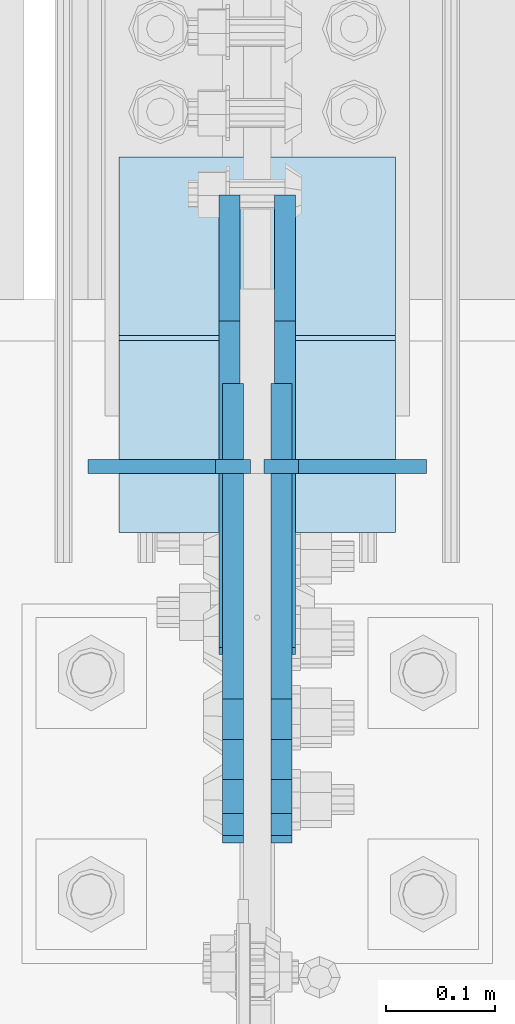
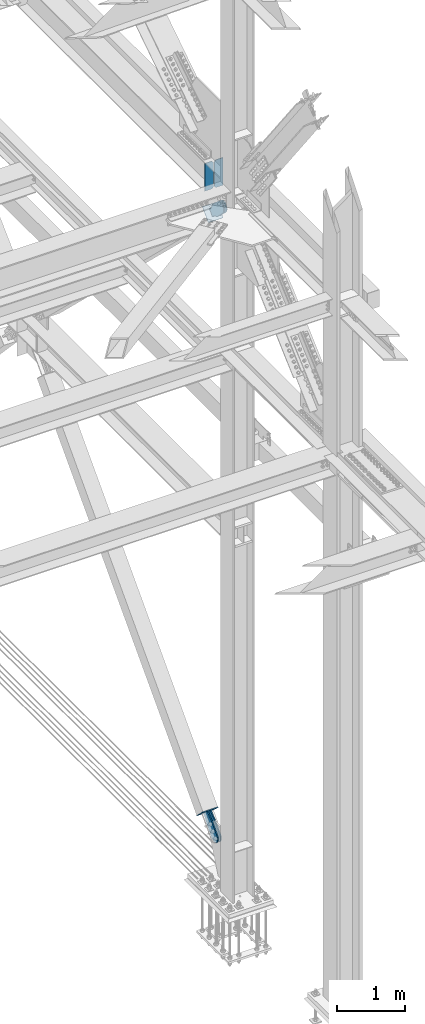
# One storey, part 3635 of 3843: 8 plates, 7 elements without a shape of their own.
"""IFC2X3 building model written with IfcOpenShell, lengths in millimetres."""

from ifc_helpers import new_model, si_unit, frame, origin_with_axes, place, context, subcontext, project, spatial, faceted_brep, material, type_object, element, aggregate, save


model = new_model("IFC2X3")

# Units and contexts
model_context = context("Model", 3, precision=1e-05, world=origin_with_axes())
body_context = subcontext(model_context, "Body", "Model", "MODEL_VIEW")
ifc_project = project(units=[si_unit("LENGTHUNIT", "METRE", prefix="MILLI"), si_unit("AREAUNIT", "SQUARE_METRE"), si_unit("VOLUMEUNIT", "CUBIC_METRE"), si_unit("MASSUNIT", "GRAM", prefix="KILO"), si_unit("TIMEUNIT", "SECOND"), si_unit("PLANEANGLEUNIT", "RADIAN"), si_unit("SOLIDANGLEUNIT", "STERADIAN"), si_unit("THERMODYNAMICTEMPERATUREUNIT", "DEGREE_CELSIUS"), si_unit("LUMINOUSINTENSITYUNIT", "LUMEN")], contexts=[model_context])

# Site, building, storey
site_placement = place(None, origin_with_axes())
site = spatial("IfcSite", under=ifc_project, at=site_placement, CompositionType="ELEMENT")
building_placement = place(site_placement, origin_with_axes())
building = spatial("IfcBuilding", under=site, at=building_placement, Name="Undefined", CompositionType="ELEMENT")
storey_placement = place(building_placement, origin_with_axes())
storey = spatial("IfcBuildingStorey", under=building, at=storey_placement, Name="Undefined", CompositionType="ELEMENT", Elevation=0.0)

# Assembly, plates
assembly_1_placement = place(storey_placement, origin_with_axes())
assembly_1 = element("IfcElementAssembly", 1, at=assembly_1_placement, inside=storey, Name="BEAM", AssemblyPlace="NOTDEFINED", PredefinedType="RIGID_FRAME")
ifc_material_1 = material(Name="STEEL/A572-50")
plate_type_1 = type_object("IfcPlateType", PredefinedType="NOTDEFINED")
plate_1_placement = place(assembly_1_placement, frame((85642.45, 92912.1863422609, 41948.1), z_axis=(0.0, 0.0, 1.0), x_axis=(-1.0, 0.0, 0.0)))
plate_1 = element("IfcPlate", 2, at=plate_1_placement, type_object=plate_type_1, material=ifc_material_1, Name="PLATE", context=body_context, shape_type="Brep", body=[
    faceted_brep([(0.0, -6.35000000000582, 31.75), (0.0, -6.35000000000582, 466.724999999999), (0.0, 6.35000000000582, 466.724999999999), (0.0, 6.35000000000582, 31.75), (31.75, -6.35000000000582, 498.474999999999), (31.75, 6.35000000000582, 498.474999999999), (149.224999999991, -6.35000000000582, 498.474999999999), (149.224999999991, 6.35000000000582, 498.474999999999), (149.224999999991, -6.35000000000582, 0.0), (149.224999999991, 6.35000000000582, 0.0), (31.75, -6.35000000000582, 0.0), (31.75, 6.35000000000582, 0.0)], [[[0, 1, 2, 3]], [[1, 4, 5, 2]], [[4, 6, 7, 5]], [[6, 8, 9, 7]], [[8, 10, 11, 9]], [[10, 0, 3, 11]], [[5, 7, 9, 11, 3, 2]], [[10, 8, 6, 4, 1, 0]]]),
])
plate_2_placement = place(assembly_1_placement, frame((85804.375, 92912.1863422609, 41948.1), z_axis=(0.0, 0.0, 1.0), x_axis=(-1.0, 0.0, 0.0)))
plate_2 = element("IfcPlate", 3, at=plate_2_placement, type_object=plate_type_1, material=ifc_material_1, Name="PLATE", context=body_context, shape_type="Brep", body=[
    faceted_brep([(0.0, -6.3499999046162, 0.0), (0.0, -6.35000000000582, 498.474999999999), (0.0, 6.35000000000582, 498.474999999999), (7.27595761418343e-12, 6.3499999046162, 0.0), (117.474999999991, -6.35000000000582, 498.474999999999), (117.474999999991, 6.35000000000582, 498.474999999999), (149.224999999991, -6.35000000000582, 466.724999999999), (149.224999999991, 6.35000000000582, 466.724999999999), (149.224999999991, -6.35000000000582, 31.75), (149.224999999991, 6.35000000000582, 31.75), (117.474999999991, -6.35000000000582, 0.0), (117.474999999991, 6.35000000000582, 0.0)], [[[0, 1, 2, 3]], [[1, 4, 5, 2]], [[4, 6, 7, 5]], [[6, 8, 9, 7]], [[8, 10, 11, 9]], [[10, 0, 3, 11]], [[5, 7, 9, 11, 3, 2]], [[10, 8, 6, 4, 1, 0]]]),
])
aggregate(assembly_1, [plate_1, plate_2])

# Assembly, plate
assembly_2_placement = place(storey_placement, origin_with_axes())
assembly_2 = element("IfcElementAssembly", 4, at=assembly_2_placement, inside=storey, AssemblyPlace="NOTDEFINED", PredefinedType="RIGID_FRAME")
ifc_material_2 = material(Name="STEEL/A36")
plate_type_2 = type_object("IfcPlateType", PredefinedType="NOTDEFINED")
plate_3_placement = place(assembly_2_placement, frame((85626.575, 92938.2727572555, 41588.5687521408), z_axis=(0.0, -0.693734394323864, -0.720230928336253), x_axis=(0.0, 0.720230928336252, -0.693734394323865)))
plate_3 = element("IfcPlate", 5, at=plate_3_placement, type_object=plate_type_2, material=ifc_material_2, context=body_context, shape_type="Brep", body=[
    faceted_brep([(0.0, -9.52500000000146, 0.0), (-101.599999996755, -9.52499999999418, -33.324272213511), (-101.599999996755, 9.52499999999418, -33.324272213511), (0.0, 9.52500000000146, 0.0), (-320.279297653902, -9.52499999999418, -33.3242722122595), (-320.279297653902, 9.52499999999418, -33.3242722122595), (-357.337405119242, -9.52499999999418, -25.9529563255783), (-357.337405119242, 9.52499999999418, -25.9529563255783), (-388.753751655597, -9.52499999999418, -4.96122468852991), (-388.753751655597, 9.52499999999418, -4.96122468852991), (-409.745483292782, -9.52499999999418, 26.4551218477136), (-409.745483292782, 9.52499999999418, 26.4551218477136), (-417.116799179586, -9.52499999999418, 63.5132262653569), (-417.116799179586, 9.52499999999418, 63.5132262653569), (-409.745483293211, -9.52499999999418, 100.57133373119), (-409.745483293211, 9.52499999999418, 100.57133373119), (-388.753751656006, -9.52499999999418, 131.987680267928), (-388.753751656006, 9.52499999999418, 131.987680267928), (-357.337405119271, -9.52499999999418, 152.97941190518), (-357.337405119271, 9.52499999999418, 152.97941190518), (-320.279299183247, -9.52499999999418, 160.350727791658), (-320.279299183247, 9.52499999999418, 160.350727791658), (-101.599999998418, -9.52499999999418, 160.350727790414), (-101.599999998418, 9.52499999999418, 160.350727790414), (-1.04046193882823e-09, -9.52499999999418, 127.02645557576), (-1.04046193882823e-09, 9.52499999999418, 127.02645557576), (69.8499999968899, -9.52499999999418, 127.026455575353), (69.8499999968899, 9.52499999999418, 127.026455575353), (69.8499999979995, -9.52499999999418, -4.00177668780088e-10), (69.8499999979995, 9.52499999999418, -4.00177668780088e-10)], [[[0, 1, 2, 3]], [[1, 4, 5, 2]], [[4, 6, 7, 5]], [[6, 8, 9, 7]], [[8, 10, 11, 9]], [[10, 12, 13, 11]], [[12, 14, 15, 13]], [[14, 16, 17, 15]], [[16, 18, 19, 17]], [[18, 20, 21, 19]], [[20, 22, 23, 21]], [[22, 24, 25, 23]], [[24, 26, 27, 25]], [[26, 28, 29, 27]], [[28, 0, 3, 29]], [[5, 7, 9, 11, 13, 15, 17, 19, 21, 23, 25, 27, 29, 3, 2]], [[28, 26, 24, 22, 20, 18, 16, 14, 12, 10, 8, 6, 4, 1, 0]]]),
])
aggregate(assembly_2, [plate_3])

assembly_3_placement = place(storey_placement, origin_with_axes())
assembly_3 = element("IfcElementAssembly", 6, at=assembly_3_placement, inside=storey, AssemblyPlace="NOTDEFINED", PredefinedType="RIGID_FRAME")
plate_4_placement = place(assembly_3_placement, frame((85671.025, 92938.2727572555, 41588.5687521408), z_axis=(0.0, -0.693734394323864, -0.720230928336253), x_axis=(0.0, 0.720230928336252, -0.693734394323865)))
plate_4 = element("IfcPlate", 7, at=plate_4_placement, type_object=plate_type_2, material=ifc_material_2, context=body_context, shape_type="Brep", body=[
    faceted_brep([(0.0, -9.52500000000146, 0.0), (-101.599999996755, -9.52499999999418, -33.324272213511), (-101.599999996755, 9.52499999999418, -33.324272213511), (0.0, 9.52500000000146, 0.0), (-320.279297653902, -9.52499999999418, -33.3242722122595), (-320.279297653902, 9.52499999999418, -33.3242722122595), (-357.337405119242, -9.52499999999418, -25.9529563255783), (-357.337405119242, 9.52499999999418, -25.9529563255783), (-388.753751655597, -9.52499999999418, -4.96122468852991), (-388.753751655597, 9.52499999999418, -4.96122468852991), (-409.745483292782, -9.52499999999418, 26.4551218477136), (-409.745483292782, 9.52499999999418, 26.4551218477136), (-417.116799179586, -9.52499999999418, 63.5132262653569), (-417.116799179586, 9.52499999999418, 63.5132262653569), (-409.745483293211, -9.52499999999418, 100.57133373119), (-409.745483293211, 9.52499999999418, 100.57133373119), (-388.753751656006, -9.52499999999418, 131.987680267928), (-388.753751656006, 9.52499999999418, 131.987680267928), (-357.337405119271, -9.52499999999418, 152.97941190518), (-357.337405119271, 9.52499999999418, 152.97941190518), (-320.279299183247, -9.52499999999418, 160.350727791658), (-320.279299183247, 9.52499999999418, 160.350727791658), (-101.599999998418, -9.52499999999418, 160.350727790414), (-101.599999998418, 9.52499999999418, 160.350727790414), (-1.04046193882823e-09, -9.52499999999418, 127.02645557576), (-1.04046193882823e-09, 9.52499999999418, 127.02645557576), (69.8499999968899, -9.52499999999418, 127.026455575353), (69.8499999968899, 9.52499999999418, 127.026455575353), (69.8499999979995, -9.52499999999418, -4.00177668780088e-10), (69.8499999979995, 9.52499999999418, -4.00177668780088e-10)], [[[0, 1, 2, 3]], [[1, 4, 5, 2]], [[4, 6, 7, 5]], [[6, 8, 9, 7]], [[8, 10, 11, 9]], [[10, 12, 13, 11]], [[12, 14, 15, 13]], [[14, 16, 17, 15]], [[16, 18, 19, 17]], [[18, 20, 21, 19]], [[20, 22, 23, 21]], [[22, 24, 25, 23]], [[24, 26, 27, 25]], [[26, 28, 29, 27]], [[28, 0, 3, 29]], [[5, 7, 9, 11, 13, 15, 17, 19, 21, 23, 25, 27, 29, 3, 2]], [[28, 26, 24, 22, 20, 18, 16, 14, 12, 10, 8, 6, 4, 1, 0]]]),
])
aggregate(assembly_3, [plate_4])

assembly_4_placement = place(storey_placement, origin_with_axes())
assembly_4 = element("IfcElementAssembly", 8, at=assembly_4_placement, inside=storey, AssemblyPlace="NOTDEFINED", PredefinedType="RIGID_FRAME")
plate_5_placement = place(assembly_4_placement, frame((85623.4, 93113.5827220127, 30521.3553816742), z_axis=(0.0, -0.728943917919311, 0.684573417924218), x_axis=(0.0, 0.684573417924221, 0.728943917919308)))
plate_5 = element("IfcPlate", 9, at=plate_5_placement, type_object=plate_type_2, material=ifc_material_2, context=body_context, shape_type="Brep", body=[
    faceted_brep([(0.0, -9.52500000000146, 0.0), (-101.599999999169, -9.52499999999418, -17.6403935107228), (-101.599999999169, 9.52499999999418, -17.6403935107228), (0.0, 9.52500000000146, 0.0), (-320.279297659972, -9.52499999999418, -17.640393512258), (-320.279297659972, 9.52499999999418, -17.640393512258), (-357.3374051259, -9.52499999999418, -10.2690776257878), (-357.3374051259, 9.52499999999418, -10.2690776257878), (-388.753751662653, -9.52499999999418, 10.7226540115298), (-388.753751662653, 9.52499999999418, 10.7226540115298), (-409.745483299826, -9.52499999999418, 42.1390005483918), (-409.745483299826, 9.52499999999418, 42.1390005483918), (-417.116799186137, -9.52499999999418, 79.1971049608474), (-417.116799186137, 9.52499999999418, 79.1971049608474), (-409.745483299252, -9.52499999999418, 116.255212426157), (-409.745483299252, 9.52499999999418, 116.255212426157), (-388.75375166202, -9.52499999999418, 147.671558962465), (-388.75375166202, 9.52499999999418, 147.671558962465), (-357.33740512564, -9.52499999999418, 168.663290599579), (-357.33740512564, 9.52499999999418, 168.663290599579), (-320.279299186061, -9.52499999999418, 176.034606486319), (-320.279299186061, 9.52499999999418, 176.034606486319), (-101.599999997048, -9.52499999999418, 176.034606487883), (-101.599999997048, 9.52499999999418, 176.034606487883), (1.71894498635083e-09, -9.52499999999418, 158.39421297863), (1.71894498635083e-09, 9.52499999999418, 158.39421297863), (69.8500000010408, -9.52499999999418, 158.394212979103), (69.8500000010408, 9.52499999999418, 158.394212979103), (69.8499999979995, -9.52499999999418, -4.00177668780088e-10), (69.8499999979995, 9.52499999999418, -4.00177668780088e-10)], [[[0, 1, 2, 3]], [[1, 4, 5, 2]], [[4, 6, 7, 5]], [[6, 8, 9, 7]], [[8, 10, 11, 9]], [[10, 12, 13, 11]], [[12, 14, 15, 13]], [[14, 16, 17, 15]], [[16, 18, 19, 17]], [[18, 20, 21, 19]], [[20, 22, 23, 21]], [[22, 24, 25, 23]], [[24, 26, 27, 25]], [[26, 28, 29, 27]], [[28, 0, 3, 29]], [[5, 7, 9, 11, 13, 15, 17, 19, 21, 23, 25, 27, 29, 3, 2]], [[28, 26, 24, 22, 20, 18, 16, 14, 12, 10, 8, 6, 4, 1, 0]]]),
])
aggregate(assembly_4, [plate_5])

assembly_5_placement = place(storey_placement, origin_with_axes())
assembly_5 = element("IfcElementAssembly", 10, at=assembly_5_placement, inside=storey, AssemblyPlace="NOTDEFINED", PredefinedType="RIGID_FRAME")
plate_6_placement = place(assembly_5_placement, frame((85674.2, 93113.5827220127, 30521.3553816742), z_axis=(0.0, -0.728943917919311, 0.684573417924218), x_axis=(0.0, 0.684573417924221, 0.728943917919308)))
plate_6 = element("IfcPlate", 11, at=plate_6_placement, type_object=plate_type_2, material=ifc_material_2, context=body_context, shape_type="Brep", body=[
    faceted_brep([(0.0, -9.52500000000146, 0.0), (-101.599999999169, -9.52499999999418, -17.6403935107228), (-101.599999999169, 9.52499999999418, -17.6403935107228), (0.0, 9.52500000000146, 0.0), (-320.279297659972, -9.52499999999418, -17.640393512258), (-320.279297659972, 9.52499999999418, -17.640393512258), (-357.3374051259, -9.52499999999418, -10.2690776257878), (-357.3374051259, 9.52499999999418, -10.2690776257878), (-388.753751662653, -9.52499999999418, 10.7226540115298), (-388.753751662653, 9.52499999999418, 10.7226540115298), (-409.745483299826, -9.52499999999418, 42.1390005483918), (-409.745483299826, 9.52499999999418, 42.1390005483918), (-417.116799186137, -9.52499999999418, 79.1971049608474), (-417.116799186137, 9.52499999999418, 79.1971049608474), (-409.745483299252, -9.52499999999418, 116.255212426157), (-409.745483299252, 9.52499999999418, 116.255212426157), (-388.75375166202, -9.52499999999418, 147.671558962465), (-388.75375166202, 9.52499999999418, 147.671558962465), (-357.33740512564, -9.52499999999418, 168.663290599579), (-357.33740512564, 9.52499999999418, 168.663290599579), (-320.279299186061, -9.52499999999418, 176.034606486319), (-320.279299186061, 9.52499999999418, 176.034606486319), (-101.599999997048, -9.52499999999418, 176.034606487883), (-101.599999997048, 9.52499999999418, 176.034606487883), (1.71894498635083e-09, -9.52499999999418, 158.39421297863), (1.71894498635083e-09, 9.52499999999418, 158.39421297863), (69.8500000010408, -9.52499999999418, 158.394212979103), (69.8500000010408, 9.52499999999418, 158.394212979103), (69.8499999979995, -9.52499999999418, -4.00177668780088e-10), (69.8499999979995, 9.52499999999418, -4.00177668780088e-10)], [[[0, 1, 2, 3]], [[1, 4, 5, 2]], [[4, 6, 7, 5]], [[6, 8, 9, 7]], [[8, 10, 11, 9]], [[10, 12, 13, 11]], [[12, 14, 15, 13]], [[14, 16, 17, 15]], [[16, 18, 19, 17]], [[18, 20, 21, 19]], [[20, 22, 23, 21]], [[22, 24, 25, 23]], [[24, 26, 27, 25]], [[26, 28, 29, 27]], [[28, 0, 3, 29]], [[5, 7, 9, 11, 13, 15, 17, 19, 21, 23, 25, 27, 29, 3, 2]], [[28, 26, 24, 22, 20, 18, 16, 14, 12, 10, 8, 6, 4, 1, 0]]]),
])
aggregate(assembly_5, [plate_6])

assembly_6_placement = place(storey_placement, origin_with_axes())
assembly_6 = element("IfcElementAssembly", 12, at=assembly_6_placement, inside=storey, Name="Plate", AssemblyPlace="NOTDEFINED", PredefinedType="RIGID_FRAME")
plate_type_3 = type_object("IfcPlateType", PredefinedType="NOTDEFINED")
plate_7_placement = place(assembly_6_placement, frame((85521.8, 92854.1285756006, 41405.1004924713), z_axis=(0.0, 0.693734394323883, 0.720230928336235), x_axis=(1.0, 0.0, 0.0)))
plate_7 = element("IfcPlate", 13, at=plate_7_placement, type_object=plate_type_3, material=ifc_material_2, Name="Plate", context=body_context, shape_type="Brep", body=[
    faceted_brep([(0.0, -3.17499999999927, 0.0), (0.0, -3.17499999965185, 254.000000005151), (0.0, 3.17500000035216, 254.000000005166), (0.0, 3.17499999999927, 0.0), (254.0, -3.17499999965185, 254.000000005151), (254.0, 3.17500000035216, 254.000000005166), (254.0, -3.17500000000291, 0.0), (254.0, 3.17499999999927, 1.45519152283669e-11)], [[[0, 1, 2, 3]], [[1, 4, 5, 2]], [[4, 6, 7, 5]], [[6, 0, 3, 7]], [[5, 7, 3, 2]], [[6, 4, 1, 0]]]),
])
aggregate(assembly_6, [plate_7])

assembly_7_placement = place(storey_placement, origin_with_axes())
assembly_7 = element("IfcElementAssembly", 14, at=assembly_7_placement, inside=storey, Name="Plate", AssemblyPlace="NOTDEFINED", PredefinedType="RIGID_FRAME")
plate_8_placement = place(assembly_7_placement, frame((85775.8, 93194.0722831244, 30537.2331272121), z_axis=(0.0, -0.728943917919311, 0.684573417924218), x_axis=(-1.0, 0.0, 0.0)))
plate_8 = element("IfcPlate", 15, at=plate_8_placement, type_object=plate_type_3, material=ifc_material_2, Name="Plate", context=body_context, shape_type="Brep", body=[
    faceted_brep([(0.0, -3.17499999999927, 0.0), (0.0, -3.17499999965185, 254.000000005151), (0.0, 3.17500000035216, 254.000000005166), (0.0, 3.17499999999927, 0.0), (254.0, -3.17499999965185, 254.000000005151), (254.0, 3.17500000035216, 254.000000005166), (254.0, -3.17500000000291, 0.0), (254.0, 3.17499999999927, 1.45519152283669e-11)], [[[0, 1, 2, 3]], [[1, 4, 5, 2]], [[4, 6, 7, 5]], [[6, 0, 3, 7]], [[5, 7, 3, 2]], [[6, 4, 1, 0]]]),
])
aggregate(assembly_7, [plate_8])

save(model, "model.ifc")
